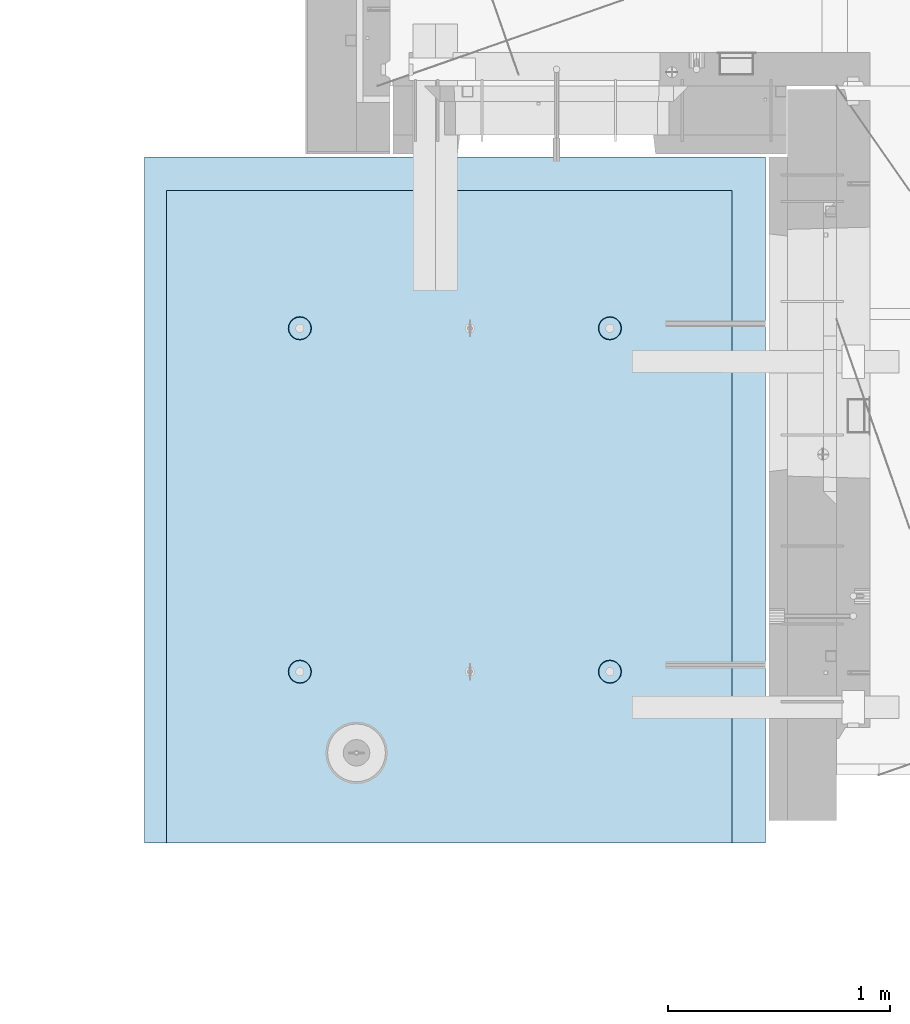
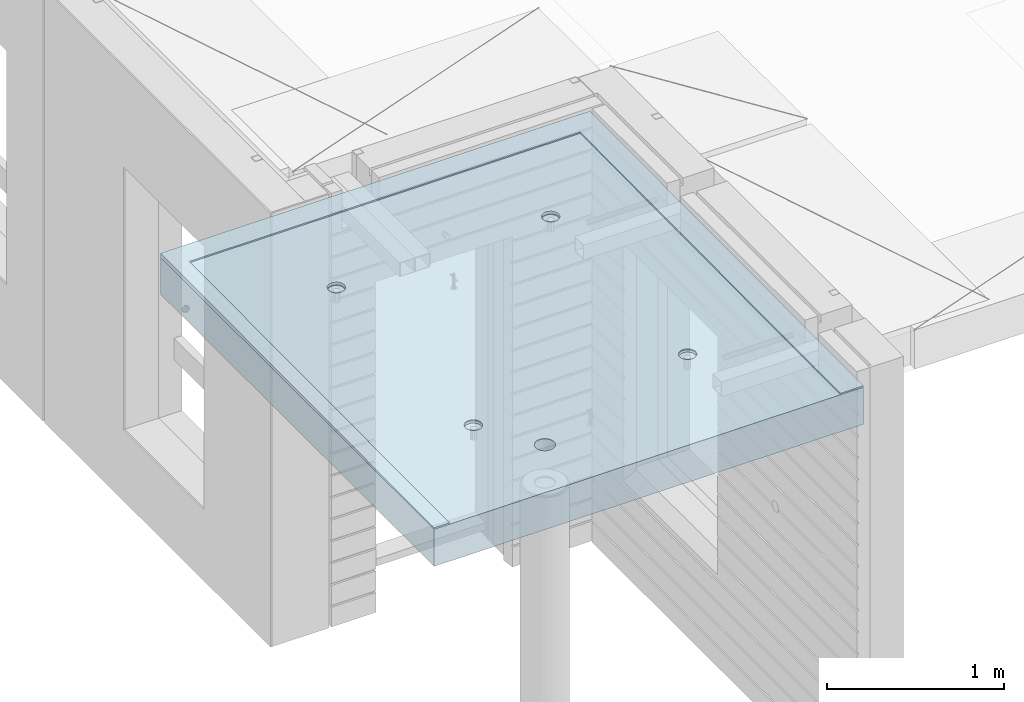
# One storey, part 171 of 309: 2 slabs, 1 element without a shape of its own.
"""IFC2X3 building model written with IfcOpenShell, lengths in millimetres."""

from ifc_helpers import new_model, si_unit, frame, origin_with_axes, place, context, subcontext, project, spatial, faceted_brep, material, type_object, element, aggregate, save


model = new_model("IFC2X3")

# Units and contexts
model_context = context("Model", 3, precision=1e-05, world=origin_with_axes())
body_context = subcontext(model_context, "Body", "Model", "MODEL_VIEW")
ifc_project = project(units=[si_unit("LENGTHUNIT", "METRE", prefix="MILLI"), si_unit("AREAUNIT", "SQUARE_METRE"), si_unit("VOLUMEUNIT", "CUBIC_METRE"), si_unit("MASSUNIT", "GRAM", prefix="KILO"), si_unit("TIMEUNIT", "SECOND"), si_unit("PLANEANGLEUNIT", "RADIAN"), si_unit("SOLIDANGLEUNIT", "STERADIAN"), si_unit("THERMODYNAMICTEMPERATUREUNIT", "DEGREE_CELSIUS"), si_unit("LUMINOUSINTENSITYUNIT", "LUMEN")], contexts=[model_context])

# Site, building, storey
site_placement = place(None, origin_with_axes())
site = spatial("IfcSite", under=ifc_project, at=site_placement, CompositionType="ELEMENT")
building_placement = place(site_placement, origin_with_axes())
building = spatial("IfcBuilding", under=site, at=building_placement, CompositionType="ELEMENT")
storey_placement = place(building_placement, origin_with_axes())
storey = spatial("IfcBuildingStorey", under=building, at=storey_placement, Name="7", CompositionType="ELEMENT", Elevation=0.0)

# Assembly, slabs
assembly_placement = place(storey_placement, origin_with_axes())
assembly = element("IfcElementAssembly", 1, at=assembly_placement, inside=storey, AssemblyPlace="NOTDEFINED", PredefinedType="REINFORCEMENT_UNIT")
ifc_material = material(Name="CONCRETE/C35/45")
slab_type_1 = type_object("IfcSlabType", PredefinedType="NOTDEFINED")
slab_1_placement = place(assembly_placement, frame((6894.99948968611, 10629.9997246798, 102715.0), z_axis=(0.0, -1.0, 0.0), x_axis=(1.0, 0.0, 0.0)))
slab_1 = element("IfcSlab", 2, at=slab_1_placement, type_object=slab_type_1, material=ifc_material, PredefinedType="FLOOR", context=body_context, shape_type="Brep", body=[
    faceted_brep([(2794.99707031249, 15.0000000000291, -0.000131364200569806), (0.0, 15.0, 0.0), (0.000144990873195638, -4.9999999999709, 3085.00317382812), (100.00014499071, -4.9999999999709, 3085.0030602745), (99.9999923706791, 14.0275536137779, 150.000004699605), (2644.99999237068, 14.0275536962727, 149.999872359604), (2645.00014498758, -4.9999999999709, 3085.00017033471), (2795.00390625, -4.9999999999709, 3085.0), (1012.06888736558, -12.1138560139225, 2661.45995738015), (1012.06888736558, -14.9999999999854, 2661.45995738015), (1015.00549551645, -14.9999999999854, 2680.00097718067), (1015.00549551645, -12.2402002112212, 2680.00097718067), (1003.5465168365, -11.9998792413244, 2644.73386150455), (1003.5465168365, -14.9999999999854, 2644.73386150455), (990.272612935421, -11.9094267340115, 2631.45995635573), (990.272612935421, -14.9999999999854, 2631.45995635573), (973.546517860922, -11.8513526136521, 2622.93758425439), (973.546517860922, -14.9999999999854, 2622.93758425439), (955.005498336445, -11.8313415797456, 2620.00097436067), (955.005498336445, -14.9999999999854, 2620.00097436067), (936.464478535928, -11.851352451733, 2622.93758251153), (936.464478535928, -14.9999999999854, 2622.93758251153), (919.738382660325, -11.9094264260348, 2631.45995304062), (919.738382660325, -14.9999999999854, 2631.45995304062), (906.464477511503, -11.9998788174125, 2644.7338569417), (906.464477511503, -14.9999999999854, 2644.7338569417), (897.942105410165, -12.1138555155921, 2661.45995201619), (897.942105410165, -14.9999999999854, 2661.45995201619), (895.005495516445, -12.2401996872504, 2680.00097154067), (895.005495516445, -14.9999999999854, 2680.00097154067), (897.942103667308, -12.3665438845201, 2698.54199134119), (897.942103667308, -14.9999999999854, 2698.54199134119), (906.464474196394, -12.4805206571182, 2715.26808721679), (906.464474196394, -14.9999999999854, 2715.26808721679), (919.73837809747, -12.5709731644311, 2728.54199236561), (919.73837809747, -14.9999999999854, 2728.54199236561), (936.464473171969, -12.6290472847904, 2737.06436446695), (936.464473171969, -14.9999999999854, 2737.06436446695), (955.005492696446, -12.6490583187115, 2740.00097436067), (955.005492696446, -14.9999999999854, 2740.00097436067), (973.546512496963, -12.6290474467241, 2737.06436620981), (973.546512496963, -14.9999999999854, 2737.06436620981), (990.272608372566, -12.5709734724223, 2728.54199568072), (990.272608372566, -14.9999999999854, 2728.54199568072), (1003.54651352139, -12.48052108103, 2715.26809177965), (1003.54651352139, -14.9999999999854, 2715.26809177965), (1012.06888562273, -12.3665443828504, 2698.54199670515), (1012.06888562273, -14.9999999999854, 2698.54199670515), (749.865931578322, -9.64283325721044, 2298.83731634233), (749.262316593716, -14.9999999999854, 2299.02552872261), (751.795494773634, -14.9999999999854, 2315.0109648098), (752.415903699642, -9.75304546006373, 2315.01096483896), (742.438136519321, -9.54337947138993, 2284.24246934354), (741.911471196561, -14.9999999999854, 2284.60708998903), (730.859427649498, -9.46444847373641, 2272.65934569806), (730.464409512111, -14.9999999999854, 2273.16840423879), (716.265583912559, -9.41379085394146, 2265.22534441055), (716.043995775316, -14.9999999999854, 2265.82916812122), (700.08916796933, -9.39637544578, 2262.66964140753), (700.063696916409, -14.9999999999854, 2263.30641692386), (683.917759955888, -9.41389907502162, 2265.24124506933), (684.088498382969, -14.9999999999854, 2265.84486437698), (669.336977920017, -9.46462350046204, 2272.68506741124), (669.68143740526, -14.9999999999854, 2273.19380088914), (657.774255308831, -9.54355433696765, 2284.2681811541), (658.250880419264, -14.9999999999854, 2284.63248556623), (650.359053670611, -9.64294107731257, 2298.8531980362), (650.913387120646, -14.9999999999854, 2299.04122186127), (647.813214575482, -9.75304500333732, 2315.01095992263), (648.385308004641, -14.9999999999854, 2315.01095994952), (650.381833197897, -9.86309629700554, 2331.16099496983), (650.913385619489, -14.9999999999854, 2330.98069827541), (657.810834157142, -9.96234522244777, 2345.72577868773), (658.250877563687, -14.9999999999854, 2345.38943526018), (669.372847702618, -10.0411056582379, 2357.28387237836), (669.681433474447, -14.9999999999854, 2356.82812101173), (683.938471939452, -10.0916921636526, 2364.70743764125), (684.088493761356, -14.9999999999854, 2364.17705887816), (700.085923109024, -10.1091630681767, 2367.27128475807), (700.063692056182, -14.9999999999854, 2366.71550783295), (716.238684639532, -10.0918003482511, 2364.72329456256), (716.043991152227, -14.9999999999854, 2364.19275813773), (730.818260796822, -10.0412807831453, 2357.30953548949), (730.464405578911, -14.9999999999854, 2356.85352337568), (742.397678727577, -9.9625205083139, 2345.75145167715), (741.911468338598, -14.9999999999854, 2345.41483870147), (749.841099841286, -9.86320488230558, 2331.1768708167), (749.262315091084, -14.9999999999854, 2330.99640065887), (2144.86593089184, -9.64283934979176, 2298.83738212138), (2144.26231659371, -14.9999999999854, 2299.02559428761), (2146.79549477363, -14.9999999999854, 2315.0110303748), (2147.41590297941, -9.75305155118986, 2315.01103040396), (2137.43813593115, -9.54338556528091, 2284.24253531574), (2136.91147119656, -14.9999999999854, 2284.60715555403), (2125.85942721456, -9.46445456868969, 2272.65941182356), (2125.46440951211, -14.9999999999854, 2273.16846980379), (2111.26558367076, -9.41379694956413, 2265.22541063444), (2111.04399577531, -14.9999999999854, 2265.82923368622), (2095.08916794162, -9.39638154160639, 2262.66970766524), (2095.06369691641, -14.9999999999854, 2263.30648248886), (2078.9177601422, -9.41390517062973, 2265.24131129301), (2079.08849838297, -14.9999999999854, 2265.84492994198), (2064.3369782993, -9.46462959540077, 2272.6851335364), (2064.68143740526, -14.9999999999854, 2273.19386645414), (2052.77425584113, -9.54356043085863, 2284.26824712596), (2053.25088041926, -14.9999999999854, 2284.63255113123), (2045.35905430105, -9.64294716989389, 2298.85326381504), (2045.91338712064, -14.9999999999854, 2299.04128742627), (2042.81321523961, -9.75305109446344, 2315.01102548763), (2043.38530800464, -14.9999999999854, 2315.01102551452), (2045.38183382804, -9.86310238666192, 2331.1610603211), (2045.91338561949, -14.9999999999854, 2330.98076384041), (2052.81083468896, -9.96235131077992, 2345.72584384624), (2053.25087756368, -14.9999999999854, 2345.38950082518), (2064.37284808142, -10.0411117455369, 2357.2839373839), (2064.68143347445, -14.9999999999854, 2356.82818657673), (2078.93847212549, -10.0916982502822, 2364.70750254855), (2079.08849376135, -14.9999999999854, 2364.17712444316), (2095.08592308136, -10.109169154588, 2367.27134963143), (2095.06369205618, -14.9999999999854, 2366.71557339795), (2111.23868439809, -10.0918064348953, 2364.72335946964), (2111.04399115223, -14.9999999999854, 2364.19282370274), (2125.81826036243, -10.0412868704298, 2357.30960049469), (2125.46440557891, -14.9999999999854, 2356.85358894068), (2137.39767813994, -9.96252659664606, 2345.75151683532), (2136.9114683386, -14.9999999999854, 2345.41490426647), (2144.84109915514, -9.86321097196196, 2331.17693616775), (2144.26231509108, -14.9999999999854, 2330.99646622387), (2144.9255213904, 0.88539012511319, 753.818823929789), (2143.1356462612, -14.9999999999854, 754.376922497695), (2145.61315019541, -14.9999999999854, 770.011030319229), (2147.47841940273, 0.775051462478586, 770.011030406895), (2137.48920352495, 0.984958026281674, 739.207230500175), (2135.94635790574, -14.9999999999854, 740.275372527487), (2125.89720900389, 1.06397959098103, 727.610816137852), (2124.75087999458, -14.9999999999854, 729.088086464069), (2111.28661998729, 1.11469533640775, 720.16828492274), (2110.64739842782, -14.9999999999854, 721.910152239194), (2095.09164288815, 1.13213072736107, 717.60964945297), (2095.01831492845, -14.9999999999854, 719.442846123091), (2078.90167946501, 1.11458699114155, 720.184203826271), (2079.39421965949, -14.9999999999854, 721.925503522301), (2064.30416713675, 1.06380436345353, 727.636567364661), (2065.30379738458, -14.9999999999854, 729.112924946283), (2052.72817721729, 0.984782960047596, 739.232971812999), (2054.12446143125, -14.9999999999854, 740.300209960133), (2045.30446722258, 0.885282181290677, 753.834723846641), (2046.94823172161, -14.9999999999854, 754.392270732209), (2042.75570697875, 0.775051919743419, 770.011025484928), (2044.47571478398, -14.9999999999854, 770.011025565769), (2045.32727288756, 0.664874350928585, 786.179591418047), (2046.94823025345, -14.9999999999854, 785.629780631745), (2052.76479803693, 0.565511545210029, 800.761087071529), (2054.12445863843, -14.9999999999854, 799.721842078387), (2064.34007807708, 0.486660738053615, 812.332442759114), (2065.30379354016, -14.9999999999854, 810.909128143092), (2078.92241521394, 0.436016188628855, 819.764525975099), (2079.39421513945, -14.9999999999854, 818.096550891574), (2095.08839430463, 0.418525237619178, 822.331314903386), (2095.01831017504, -14.9999999999854, 820.579209759453), (2111.25968984948, 0.435907879902516, 819.780401090968), (2110.64739390634, -14.9999999999854, 818.111905112482), (2125.85599491551, 0.486485412198817, 812.35813531663), (2124.75087614782, -14.9999999999854, 810.933972213332), (2137.44869931109, 0.565336058221874, 800.786789518672), (2135.94635511059, -14.9999999999854, 799.746687202289), (2144.90066116091, 0.664765641035046, 786.195485481183), (2143.13564479159, -14.9999999999854, 785.645137907874), (670.303793540164, -14.9999999999854, 810.909062578092), (669.34007769828, 0.486666825367138, 812.332377753573), (683.9224150279, 0.43602227527299, 819.764461067805), (684.394215139449, -14.9999999999854, 818.096485326574), (659.124458638432, -14.9999999999854, 799.721776513386), (657.764797505112, 0.565517633556738, 800.761021913024), (651.948230253448, -14.9999999999854, 785.629715066745), (650.327272257426, 0.664880440599518, 786.179526066784), (649.47571478398, -14.9999999999854, 770.010960000767), (647.755706314613, 0.775058010869543, 770.010959919928), (651.948231721612, -14.9999999999854, 754.392205167209), (650.304466592134, 0.885288273871993, 753.834658067803), (659.124461431248, -14.9999999999854, 740.300144395133), (657.728176684986, 0.984789053938584, 739.232905841134), (670.303797384586, -14.9999999999854, 729.112859381283), (669.304166757469, 1.06381045839225, 727.6365012395), (684.394219659487, -14.9999999999854, 721.925437957301), (683.901679278702, 1.11459308674966, 720.184137602595), (700.018314928455, -14.9999999999854, 719.442780558089), (700.091642915865, 1.13213682320202, 717.609583195261), (715.647398427825, -14.9999999999854, 721.910086674192), (716.286620229084, 1.11470143200131, 720.168218698855), (729.75087999458, -14.9999999999854, 729.088020899069), (730.897209438824, 1.06398568593431, 727.610750012351), (740.946357905746, -14.9999999999854, 740.275306962489), (742.489204113123, 0.984964120187215, 739.20716452797), (748.135646261204, -14.9999999999854, 754.376856932695), (749.925522076876, 0.885396217694506, 753.818758150739), (2645.00014498758, -15.0, 3085.00017033471), (2644.99999237068, 4.99999999947613, 149.999872359604), (100.0, 5.0, 150.0), (100.00014499071, -15.0, 3085.0030602745), (742.448699898732, 0.565342146583134, 800.786724360507), (730.855995349901, 0.48649149951234, 812.358070311429), (716.259690090917, 0.435913966532098, 819.780336183881), (700.088394332295, 0.418531324030482, 822.331250030024), (752.478420122958, 0.775057553604711, 770.010964841895), (749.900661847058, 0.664771730691427, 786.195420130131), (700.018310175045, -14.9999999999854, 820.579144194453), (715.647393906344, -14.9999999999854, 818.111839547482), (729.750876147824, -14.9999999999854, 810.933906648332), (740.946355110594, -14.9999999999854, 799.746621637289), (748.135644791598, -14.9999999999854, 785.645072342873), (750.613150195409, -14.9999999999854, 770.010964754227), (0.000144990873195638, -15.0, 3085.00317382812), (0.0, -15.0, 0.0), (2794.9970703125, -15.0, -5.76619640924037e-10), (2795.00390625, -15.0, 3085.0)], [[[0, 1, 2, 3, 4, 5, 6, 7]], [[8, 9, 10, 11]], [[12, 13, 9, 8]], [[14, 15, 13, 12]], [[16, 17, 15, 14]], [[18, 19, 17, 16]], [[20, 21, 19, 18]], [[22, 23, 21, 20]], [[24, 25, 23, 22]], [[26, 27, 25, 24]], [[28, 29, 27, 26]], [[30, 31, 29, 28]], [[32, 33, 31, 30]], [[34, 35, 33, 32]], [[36, 37, 35, 34]], [[38, 39, 37, 36]], [[40, 41, 39, 38]], [[42, 43, 41, 40]], [[44, 45, 43, 42]], [[46, 47, 45, 44]], [[11, 10, 47, 46]], [[48, 49, 50, 51]], [[52, 53, 49, 48]], [[54, 55, 53, 52]], [[56, 57, 55, 54]], [[58, 59, 57, 56]], [[60, 61, 59, 58]], [[62, 63, 61, 60]], [[63, 62, 64, 65]], [[65, 64, 66, 67]], [[67, 66, 68, 69]], [[69, 68, 70, 71]], [[71, 70, 72, 73]], [[73, 72, 74, 75]], [[75, 74, 76, 77]], [[77, 76, 78, 79]], [[79, 78, 80, 81]], [[82, 83, 81, 80]], [[84, 85, 83, 82]], [[86, 87, 85, 84]], [[51, 50, 87, 86]], [[88, 89, 90, 91]], [[92, 93, 89, 88]], [[94, 95, 93, 92]], [[96, 97, 95, 94]], [[98, 99, 97, 96]], [[100, 101, 99, 98]], [[102, 103, 101, 100]], [[103, 102, 104, 105]], [[105, 104, 106, 107]], [[107, 106, 108, 109]], [[109, 108, 110, 111]], [[111, 110, 112, 113]], [[113, 112, 114, 115]], [[115, 114, 116, 117]], [[117, 116, 118, 119]], [[119, 118, 120, 121]], [[122, 123, 121, 120]], [[124, 125, 123, 122]], [[126, 127, 125, 124]], [[91, 90, 127, 126]], [[128, 129, 130, 131]], [[132, 133, 129, 128]], [[134, 135, 133, 132]], [[136, 137, 135, 134]], [[138, 139, 137, 136]], [[140, 141, 139, 138]], [[141, 140, 142, 143]], [[143, 142, 144, 145]], [[145, 144, 146, 147]], [[147, 146, 148, 149]], [[149, 148, 150, 151]], [[151, 150, 152, 153]], [[153, 152, 154, 155]], [[155, 154, 156, 157]], [[157, 156, 158, 159]], [[160, 161, 159, 158]], [[162, 163, 161, 160]], [[164, 165, 163, 162]], [[166, 167, 165, 164]], [[131, 130, 167, 166]], [[168, 169, 170, 171]], [[172, 173, 169, 168]], [[174, 175, 173, 172]], [[176, 177, 175, 174]], [[178, 179, 177, 176]], [[180, 181, 179, 178]], [[182, 183, 181, 180]], [[184, 185, 183, 182]], [[185, 184, 186, 187]], [[187, 186, 188, 189]], [[189, 188, 190, 191]], [[191, 190, 192, 193]], [[193, 192, 194, 195]], [[196, 197, 198, 199], [200, 201, 202, 203, 170, 169, 173, 175, 177, 179, 181, 183, 185, 187, 189, 191, 193, 195, 204, 205], [164, 162, 160, 158, 156, 154, 152, 150, 148, 146, 144, 142, 140, 138, 136, 134, 132, 128, 131, 166], [124, 122, 120, 118, 116, 114, 112, 110, 108, 106, 104, 102, 100, 98, 96, 94, 92, 88, 91, 126], [84, 82, 80, 78, 76, 74, 72, 70, 68, 66, 64, 62, 60, 58, 56, 54, 52, 48, 51, 86], [44, 42, 40, 38, 36, 34, 32, 30, 28, 26, 24, 22, 20, 18, 16, 14, 12, 8, 11, 46]], [[171, 170, 203, 206]], [[202, 207, 206, 203]], [[201, 208, 207, 202]], [[200, 209, 208, 201]], [[205, 210, 209, 200]], [[204, 211, 210, 205]], [[195, 194, 211, 204]], [[212, 213, 214, 215, 196, 199], [192, 190, 188, 186, 184, 182, 180, 178, 176, 174, 172, 168, 171, 206, 207, 208, 209, 210, 211, 194], [133, 135, 137, 139, 141, 143, 145, 147, 149, 151, 153, 155, 157, 159, 161, 163, 165, 167, 130, 129], [93, 95, 97, 99, 101, 103, 105, 107, 109, 111, 113, 115, 117, 119, 121, 123, 125, 127, 90, 89], [53, 55, 57, 59, 61, 63, 65, 67, 69, 71, 73, 75, 77, 79, 81, 83, 85, 87, 50, 49], [13, 15, 17, 19, 21, 23, 25, 27, 29, 31, 33, 35, 37, 39, 41, 43, 45, 47, 10, 9]], [[215, 214, 0, 7]], [[196, 215, 7, 6]], [[197, 196, 6, 5]], [[198, 197, 5, 4]], [[199, 198, 4, 3]], [[212, 199, 3, 2]], [[213, 212, 2, 1]], [[214, 213, 1, 0]]]),
])
slab_type_2 = type_object("IfcSlabType", PredefinedType="NOTDEFINED")
slab_2_placement = place(assembly_placement, frame((9690.00344264774, 7544.99985681325, 102572.5), z_axis=(-0.999999999997437, -2.26400000064461e-06, 0.0), x_axis=(-2.2639999995273e-06, 0.999999999997437, 0.0)))
slab_2 = element("IfcSlab", 3, at=slab_2_placement, type_object=slab_type_2, material=ifc_material, PredefinedType="FLOOR", context=body_context, shape_type="Brep", body=[
    faceted_brep([(62.5060439462522, 122.500580807275, 2737.50302930925), (60.0057558708622, 117.500007850016, 2737.50303346509), (55.0057558996605, 127.500007781375, 2737.50304462009), (60.0059759501419, 127.500429964581, 2737.50303488676), (60.0059752390926, 122.500581162807, 2737.50303417581), (60.0059696614244, 117.500430245345, 2735.00295871432), (60.0005429506346, 117.5003886989, 59.5030334701896), (55.0005429794337, 127.500388630258, 59.5030446251894), (65.0005456852132, 127.500387781736, 59.5030251594617), (65.0057440060555, 127.500428617161, 2730.0029462473), (3085.0, -127.5, -1.17870513349772e-09), (-9.09494701772928e-13, -127.5, 1.81898940354586e-12), (-9.09494701772928e-13, 127.5, 1.81898940354586e-12), (3085.0, 127.5, -1.17870513349772e-09), (3085.00610351562, -127.5, 2794.9970703125), (3085.00610351562, 127.5, 2794.9970703125), (0.00285872398035281, -127.5, 2795.00366210938), (0.00285872398035281, 127.5, 2795.00366210938), (785.444355982238, -112.283853005254, 2047.4542445988), (799.382784722427, -112.316134384208, 2054.5561162318), (810.444396504666, -112.366413810698, 2065.61756438665), (817.546403696938, -112.429769584152, 2079.55581744832), (819.993612352663, -112.500000000044, 2095.00650209361), (817.546472637917, -112.570230415935, 2110.45719765819), (810.4445276382, -112.633586189389, 2124.39548240888), (799.382965212254, -112.68386561588, 2135.45697992053), (785.444568160755, -112.716146994833, 2142.55891374673), (769.993723901635, -112.727270399948, 2145.00609712247), (754.542868723337, -112.716146994833, 2142.55898268842), (740.604439983151, -112.68386561588, 2135.45711105542), (729.542828200908, -112.633586189389, 2124.39566290057), (722.440821008639, -112.570230415935, 2110.4574098389), (719.993612352912, -112.500000000044, 2095.00672519361), (722.44075206766, -112.429769584152, 2079.55602962903), (729.542697067373, -112.366413810698, 2065.61774487834), (740.604259493323, -112.316134384208, 2054.55624736669), (754.542656544821, -112.283853005254, 2047.45431354049), (769.99350080394, -112.272729600139, 2045.00713016475), (785.978938406634, -127.5, 2045.73977479981), (769.993496787028, -127.5, 2043.20663153209), (800.397393194428, -127.5, 2053.09058870707), (811.836103945022, -127.5, 2064.5376254094), (819.175371556757, -127.5, 2078.95802311727), (821.698157655089, -127.5, 2094.93831646645), (819.159745091803, -127.5, 2110.91352054382), (811.810840044681, -127.5, 2125.32059757157), (800.372180331961, -127.5, 2136.75117953963), (785.963460062038, -127.5, 2144.08870430691), (769.993727495154, -127.5, 2146.61681830081), (754.023983647986, -127.5, 2144.08877556388), (739.615230638169, -127.5, 2136.75131508838), (728.176519922309, -127.5, 2125.32078415974), (720.827550590881, -127.5, 2110.91373992295), (718.289066746257, -127.5, 2094.93854717213), (720.811781540496, -127.5, 2078.95824256644), (728.150984808343, -127.5, 2064.5378121109), (739.589644482144, -127.5, 2053.09072436916), (754.008066470465, -127.5, 2045.73984612682), (2330.44435597839, -122.283853005254, 2047.4507977038), (2344.38278471858, -122.316134384208, 2054.5526693368), (2355.44439650082, -122.366413810698, 2065.61411749165), (2362.54640369309, -122.429769584152, 2079.55237055332), (2364.99361234882, -122.500000000044, 2095.00305519861), (2362.54647263407, -122.570230415935, 2110.45375076319), (2355.44452763436, -122.633586189389, 2124.39203551388), (2344.38296520841, -122.68386561588, 2135.45353302553), (2330.44456815691, -122.716146994833, 2142.55546685173), (2314.99372389779, -122.727270399948, 2145.00265022747), (2299.54286871949, -122.716146994833, 2142.55553579342), (2285.60443997931, -122.68386561588, 2135.45366416042), (2274.54282819706, -122.633586189389, 2124.39221600557), (2267.44082100479, -122.570230415935, 2110.4539629439), (2264.99361234907, -122.500000000044, 2095.00327829861), (2267.44075206382, -122.429769584152, 2079.55258273403), (2274.54269706353, -122.366413810698, 2065.61429798334), (2285.60425948948, -122.316134384208, 2054.55280047169), (2299.54265654098, -122.283853005254, 2047.45086664549), (2314.99350080009, -122.272729600139, 2045.00368326975), (2330.62761265352, -127.5, 2046.86307161962), (2314.99349942116, -127.5, 2044.38560183031), (2344.7291783251, -127.5, 2054.05232917727), (2355.91648883941, -127.5, 2065.24778265538), (2363.09445386627, -127.5, 2079.35124854549), (2365.56179411629, -127.5, 2094.98032665622), (2363.07917084011, -127.5, 2110.60442734728), (2355.89178018963, -127.5, 2124.69486531947), (2344.70451959147, -127.5, 2135.87422570581), (2330.61247449232, -127.5, 2143.05048619249), (2314.99372505877, -127.5, 2145.52303724148), (2299.37496459286, -127.5, 2143.05055588338), (2285.28288747337, -127.5, 2135.87435827548), (2274.09557699303, -127.5, 2124.6950478068), (2266.90812347108, -127.5, 2110.60464190488), (2264.42543048019, -127.5, 2094.98055229145), (2266.89270099323, -127.5, 2079.3514631716), (2274.07060309036, -127.5, 2065.24796525355), (2285.25786365045, -127.5, 2054.05246185777), (2299.35939724342, -127.5, 2046.86314137901), (785.441243737238, -112.283853005254, 652.454244602275), (799.379672477427, -112.316134384208, 659.55611623527), (810.441284259666, -112.366413810698, 670.617564390122), (817.543291451936, -112.429769584152, 684.555817451792), (819.990500107661, -112.500000000044, 700.006502097083), (817.543360392917, -112.570230415935, 715.457197661666), (810.4414153932, -112.633586189389, 729.395482412354), (799.379852967252, -112.68386561588, 740.456979924005), (785.441455915755, -112.716146994833, 747.558913750199), (769.990611656635, -112.727270399948, 750.006097125943), (754.539756478337, -112.716146994833, 747.558982691891), (740.601327738149, -112.68386561588, 740.457111058895), (729.539715955908, -112.633586189389, 729.395662904044), (722.437708763639, -112.570230415935, 715.457409842375), (719.990500107911, -112.500000000044, 700.006725197083), (722.437639822659, -112.429769584152, 684.5560296325), (729.539584822373, -112.366413810698, 670.617744881813), (740.601147248323, -112.316134384208, 659.556247370159), (754.539544299821, -112.283853005254, 652.454313543967), (769.99038855894, -112.272729600139, 650.007130168222), (785.975826161634, -127.5, 650.739774803276), (769.990384542028, -127.5, 648.206631535557), (800.394280949428, -127.5, 658.090588710544), (811.832991700022, -127.5, 669.537625412873), (819.172259311757, -127.5, 683.958023120746), (821.695045410089, -127.5, 699.938316469923), (819.156632846801, -127.5, 715.913520547292), (811.807727799679, -127.5, 730.320597575044), (800.369068086961, -127.5, 741.751179543102), (785.960347817038, -127.5, 749.088704310381), (769.990615250154, -127.5, 751.616818304288), (754.020871402986, -127.5, 749.088775567352), (739.612118393169, -127.5, 741.751315091857), (728.173407677307, -127.5, 730.320784163212), (720.82443834588, -127.5, 715.913739926418), (718.285954501257, -127.5, 699.938547175605), (720.808669295496, -127.5, 683.958242569914), (728.147872563343, -127.5, 669.537812114375), (739.586532237144, -127.5, 658.090724372631), (754.004954225465, -127.5, 650.739846130293), (2330.44124373339, -122.283853005254, 652.450797707275), (2344.37967247358, -122.316134384208, 659.55266934027), (2355.44128425582, -122.366413810698, 670.614117495123), (2362.54329144809, -122.429769584152, 684.552370556792), (2364.99050010382, -122.500000000044, 700.003055202083), (2362.54336038907, -122.570230415935, 715.453750766666), (2355.44141538936, -122.633586189389, 729.392035517354), (2344.37985296341, -122.68386561588, 740.453533029005), (2330.44145591191, -122.716146994833, 747.555466855199), (2314.99061165279, -122.727270399948, 750.002650230943), (2299.53975647449, -122.716146994833, 747.555535796891), (2285.6013277343, -122.68386561588, 740.453664163895), (2274.53971595206, -122.633586189389, 729.392216009044), (2267.43770875979, -122.570230415935, 715.453962947375), (2264.99050010407, -122.500000000044, 700.003278302083), (2267.43763981881, -122.429769584152, 684.5525827375), (2274.53958481853, -122.366413810698, 670.614297986813), (2285.60114724448, -122.316134384208, 659.55280047516), (2299.53954429598, -122.283853005254, 652.450866648967), (2314.99038855509, -122.272729600139, 650.003683273222), (2330.62450040852, -127.5, 651.863071623089), (2314.99038717616, -127.5, 649.385601833779), (2344.7260660801, -127.5, 659.052329180744), (2355.91337659441, -127.5, 670.247782658847), (2363.09134162127, -127.5, 684.351248548961), (2365.55868187129, -127.5, 699.980326659697), (2363.07605859511, -127.5, 715.604427350749), (2355.88866794463, -127.5, 729.694865322945), (2344.70140734647, -127.5, 740.874225709285), (2330.60936224732, -127.5, 748.050486195965), (2314.99061281377, -127.5, 750.523037244951), (2299.37185234786, -127.5, 748.05055588685), (2285.27977522837, -127.5, 740.874358278947), (2274.09246474803, -127.5, 729.695047810274), (2266.90501122608, -127.5, 715.604641908356), (2264.42231823518, -127.5, 699.980552294925), (2266.88958874823, -127.5, 684.351463175071), (2274.06749084536, -127.5, 670.247965257018), (2285.25475140545, -127.5, 659.052461861247), (2299.35628499842, -127.5, 651.863141382479), (369.735819993911, -127.5, 1791.45648694649), (356.461945083075, -127.5, 1804.73042108549), (347.939611083803, -127.5, 1821.45653557391), (345.003043426535, -127.5, 1839.99756178794), (347.939693813832, -127.5, 1858.53857489881), (356.462102444943, -127.5, 1875.26465136041), (369.73603658394, -127.5, 1888.53852627125), (386.46215107236, -127.5, 1897.06086027052), (405.003177286385, -127.5, 1899.99742792779), (423.544190397261, -127.5, 1897.06077754049), (440.270266858861, -127.5, 1888.53836890938), (453.544141769695, -127.5, 1875.26443477038), (462.066475768966, -127.5, 1858.53832028196), (465.003043426236, -127.5, 1839.99729406794), (462.066393038937, -127.5, 1821.45628095706), (453.543984407827, -127.5, 1804.73020449546), (440.270050268831, -127.5, 1791.45632958463), (423.543935780411, -127.5, 1782.93399558535), (405.002909566385, -127.5, 1779.99742792808), (386.461896455509, -127.5, 1782.93407831538), (440.270050268831, 127.5, 1791.45632958463), (423.543935780411, 127.5, 1782.93399558535), (453.543984407827, 127.5, 1804.73020449546), (462.066393038937, 127.5, 1821.45628095706), (465.003043426236, 127.5, 1839.99729406794), (462.066475768966, 127.5, 1858.53832028196), (453.544141769695, 127.5, 1875.26443477038), (440.270266858861, 127.5, 1888.53836890938), (423.544190397261, 127.5, 1897.06077754049), (405.003177286385, 127.5, 1899.99742792779), (386.46215107236, 127.5, 1897.06086027052), (369.73603658394, 127.5, 1888.53852627125), (356.462102444943, 127.5, 1875.26465136041), (347.939693813832, 127.5, 1858.53857489881), (345.003043426535, 127.5, 1839.99756178794), (347.939611083803, 127.5, 1821.45653557391), (356.461945083075, 127.5, 1804.73042108549), (369.735819993911, 127.5, 1791.45648694649), (386.461896455509, 127.5, 1782.93407831538), (405.002909566385, 127.5, 1779.99742792808), (3020.00576146453, 127.500009223528, 2739.99719683237), (3025.00576143424, 117.500007865223, 2739.99641855006), (3025.00596965578, 117.500008581061, 2734.99718712789), (3030.00576416882, 127.500006948059, 2739.99641023933), (3025.00598081078, 127.500008512434, 2739.99718709909), (3030.00440156831, 127.500106497799, 2039.99641024067), (3025.00439883373, 117.500107414962, 2039.99641855139), (3020.00439886253, 127.500107346321, 2039.99642970639), (3020.0057419988, 127.500008375006, 2729.99719412659), (60.0059808164242, 127.500430176704, 2740.00295868552)], [[[0, 1, 2, 3, 4]], [[5, 1, 0]], [[2, 1, 5, 6, 7]], [[8, 6, 5, 9]], [[7, 6, 8]], [[10, 11, 12, 13]], [[14, 10, 13, 15]], [[16, 14, 15, 17]], [[11, 16, 17, 12]], [[18, 19, 20, 21, 22, 23, 24, 25, 26, 27, 28, 29, 30, 31, 32, 33, 34, 35, 36, 37]], [[38, 18, 37, 39]], [[40, 19, 18, 38]], [[41, 20, 19, 40]], [[42, 21, 20, 41]], [[43, 22, 21, 42]], [[44, 23, 22, 43]], [[45, 24, 23, 44]], [[46, 25, 24, 45]], [[47, 26, 25, 46]], [[48, 27, 26, 47]], [[49, 28, 27, 48]], [[50, 29, 28, 49]], [[51, 30, 29, 50]], [[52, 31, 30, 51]], [[53, 32, 31, 52]], [[54, 33, 32, 53]], [[55, 34, 33, 54]], [[56, 35, 34, 55]], [[57, 36, 35, 56]], [[39, 37, 36, 57]], [[58, 59, 60, 61, 62, 63, 64, 65, 66, 67, 68, 69, 70, 71, 72, 73, 74, 75, 76, 77]], [[78, 58, 77, 79]], [[80, 59, 58, 78]], [[81, 60, 59, 80]], [[82, 61, 60, 81]], [[83, 62, 61, 82]], [[84, 63, 62, 83]], [[85, 64, 63, 84]], [[86, 65, 64, 85]], [[87, 66, 65, 86]], [[88, 67, 66, 87]], [[89, 68, 67, 88]], [[90, 69, 68, 89]], [[91, 70, 69, 90]], [[92, 71, 70, 91]], [[93, 72, 71, 92]], [[94, 73, 72, 93]], [[95, 74, 73, 94]], [[96, 75, 74, 95]], [[97, 76, 75, 96]], [[79, 77, 76, 97]], [[98, 99, 100, 101, 102, 103, 104, 105, 106, 107, 108, 109, 110, 111, 112, 113, 114, 115, 116, 117]], [[118, 98, 117, 119]], [[120, 99, 98, 118]], [[121, 100, 99, 120]], [[122, 101, 100, 121]], [[123, 102, 101, 122]], [[124, 103, 102, 123]], [[125, 104, 103, 124]], [[126, 105, 104, 125]], [[127, 106, 105, 126]], [[128, 107, 106, 127]], [[129, 108, 107, 128]], [[130, 109, 108, 129]], [[131, 110, 109, 130]], [[132, 111, 110, 131]], [[133, 112, 111, 132]], [[134, 113, 112, 133]], [[135, 114, 113, 134]], [[136, 115, 114, 135]], [[137, 116, 115, 136]], [[119, 117, 116, 137]], [[138, 139, 140, 141, 142, 143, 144, 145, 146, 147, 148, 149, 150, 151, 152, 153, 154, 155, 156, 157]], [[158, 138, 157, 159]], [[160, 139, 138, 158]], [[161, 140, 139, 160]], [[162, 141, 140, 161]], [[163, 142, 141, 162]], [[164, 143, 142, 163]], [[165, 144, 143, 164]], [[166, 145, 144, 165]], [[167, 146, 145, 166]], [[168, 147, 146, 167]], [[169, 148, 147, 168]], [[170, 149, 148, 169]], [[171, 150, 149, 170]], [[172, 151, 150, 171]], [[173, 152, 151, 172]], [[174, 153, 152, 173]], [[175, 154, 153, 174]], [[176, 155, 154, 175]], [[177, 156, 155, 176]], [[159, 157, 156, 177]], [[10, 14, 16, 11], [176, 175, 174, 173, 172, 171, 170, 169, 168, 167, 166, 165, 164, 163, 162, 161, 160, 158, 159, 177], [136, 135, 134, 133, 132, 131, 130, 129, 128, 127, 126, 125, 124, 123, 122, 121, 120, 118, 119, 137], [96, 95, 94, 93, 92, 91, 90, 89, 88, 87, 86, 85, 84, 83, 82, 81, 80, 78, 79, 97], [56, 55, 54, 53, 52, 51, 50, 49, 48, 47, 46, 45, 44, 43, 42, 41, 40, 38, 39, 57], [178, 179, 180, 181, 182, 183, 184, 185, 186, 187, 188, 189, 190, 191, 192, 193, 194, 195, 196, 197]], [[194, 198, 199, 195]], [[193, 200, 198, 194]], [[192, 201, 200, 193]], [[191, 202, 201, 192]], [[190, 203, 202, 191]], [[189, 204, 203, 190]], [[188, 205, 204, 189]], [[187, 206, 205, 188]], [[186, 207, 206, 187]], [[185, 208, 207, 186]], [[184, 209, 208, 185]], [[183, 210, 209, 184]], [[182, 211, 210, 183]], [[181, 212, 211, 182]], [[180, 213, 212, 181]], [[179, 214, 213, 180]], [[178, 215, 214, 179]], [[197, 216, 215, 178]], [[196, 217, 216, 197]], [[195, 199, 217, 196]], [[218, 219, 220]], [[221, 219, 218, 222]], [[223, 224, 220, 219, 221]], [[225, 224, 223]], [[226, 220, 224, 225]], [[220, 226, 9, 5]], [[4, 227, 218, 220, 5, 0]], [[227, 4, 3]], [[15, 13, 12, 17], [226, 225, 223, 221, 222, 218, 227, 3, 2, 7, 8, 9], [198, 200, 201, 202, 203, 204, 205, 206, 207, 208, 209, 210, 211, 212, 213, 214, 215, 216, 217, 199]]]),
])
aggregate(assembly, [slab_1, slab_2])

save(model, "model.ifc")
